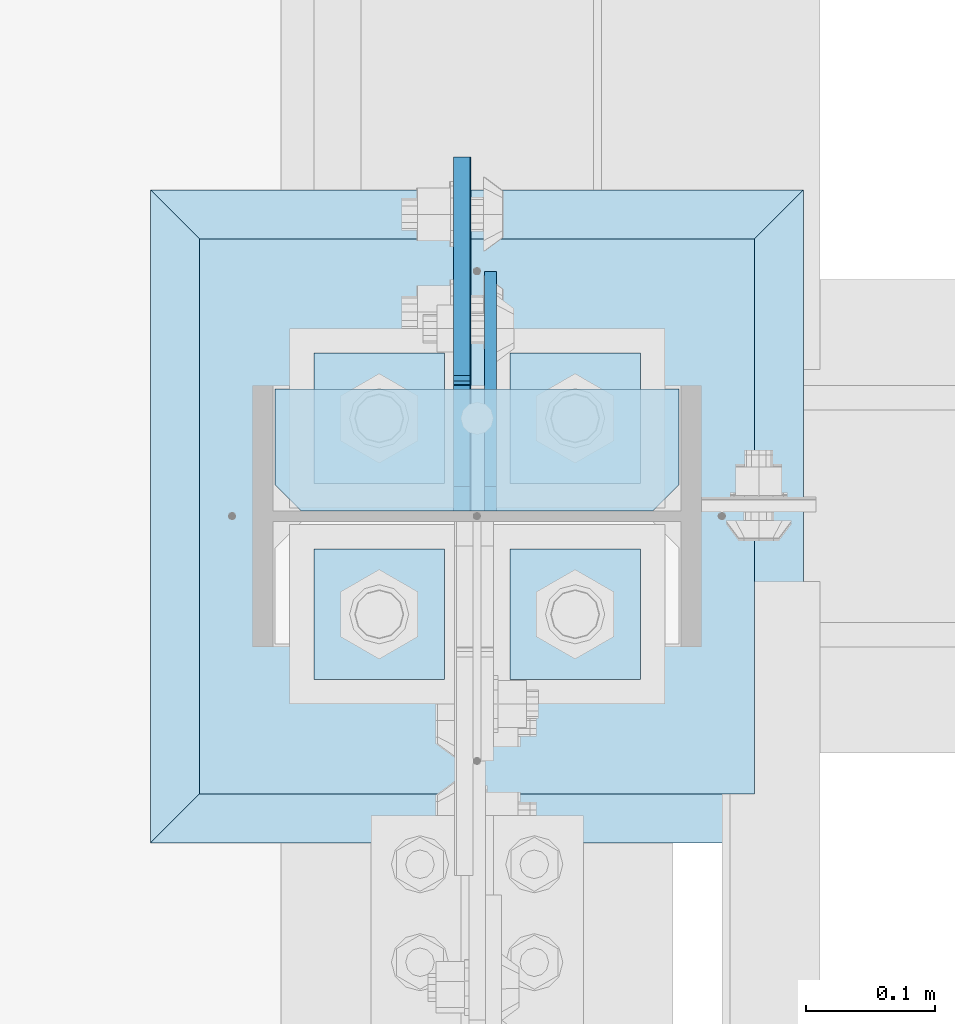
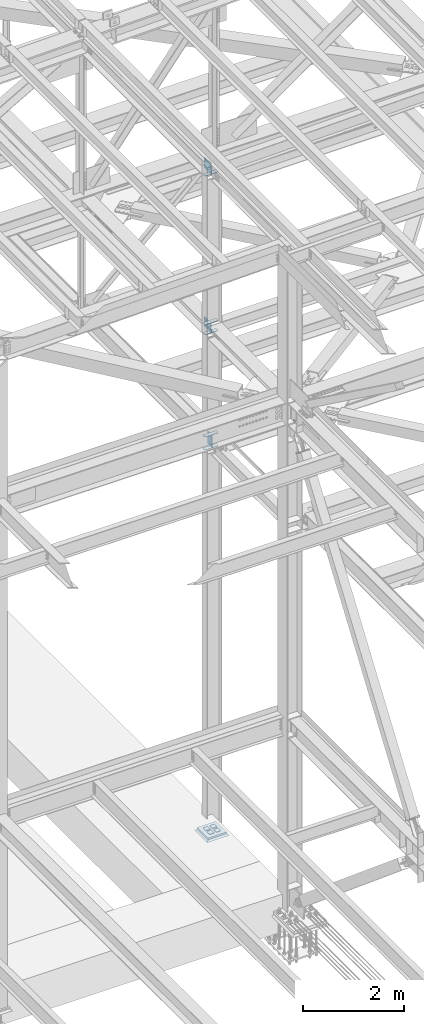
# One storey, part 3203 of 3843: 14 plates, 3 elements without a shape of their own.
"""IFC2X3 building model written with IfcOpenShell, lengths in millimetres."""

from ifc_helpers import new_model, si_unit, frame, origin_with_axes, place, context, subcontext, project, spatial, faceted_brep, material, type_object, element, aggregate, save


model = new_model("IFC2X3")

# Units and contexts
model_context = context("Model", 3, precision=1e-05, world=origin_with_axes())
body_context = subcontext(model_context, "Body", "Model", "MODEL_VIEW")
ifc_project = project(units=[si_unit("LENGTHUNIT", "METRE", prefix="MILLI"), si_unit("AREAUNIT", "SQUARE_METRE"), si_unit("VOLUMEUNIT", "CUBIC_METRE"), si_unit("MASSUNIT", "GRAM", prefix="KILO"), si_unit("TIMEUNIT", "SECOND"), si_unit("PLANEANGLEUNIT", "RADIAN"), si_unit("SOLIDANGLEUNIT", "STERADIAN"), si_unit("THERMODYNAMICTEMPERATUREUNIT", "DEGREE_CELSIUS"), si_unit("LUMINOUSINTENSITYUNIT", "LUMEN")], contexts=[model_context])

# Site, building, storey
site_placement = place(None, origin_with_axes())
site = spatial("IfcSite", under=ifc_project, at=site_placement, CompositionType="ELEMENT")
building_placement = place(site_placement, origin_with_axes())
building = spatial("IfcBuilding", under=site, at=building_placement, Name="Undefined", CompositionType="ELEMENT")
storey_placement = place(building_placement, origin_with_axes())
storey = spatial("IfcBuildingStorey", under=building, at=storey_placement, Name="Undefined", CompositionType="ELEMENT", Elevation=0.0)

# Assembly, plates
assembly_1_placement = place(storey_placement, origin_with_axes())
assembly_1 = element("IfcElementAssembly", 1, at=assembly_1_placement, inside=storey, Name="COLUMN", AssemblyPlace="NOTDEFINED", PredefinedType="RIGID_FRAME")
ifc_material_1 = material(Name="STEEL/A572-50")
plate_type_1 = type_object("IfcPlateType", PredefinedType="NOTDEFINED")
plate_1_placement = place(assembly_1_placement, frame((77169.9625, 28813.91875, 39336.6625), z_axis=(-1.0, 0.0, 0.0), x_axis=(0.0, -1.0, 0.0)))
plate_1 = element("IfcPlate", 2, at=plate_1_placement, type_object=plate_type_1, material=ifc_material_1, Name="PLATE", context=body_context, shape_type="Brep", body=[
    faceted_brep([(0.0, -4.76249999999709, 0.0), (0.0, -4.76249999999709, 314.324999999997), (0.0, 4.76249999999709, 314.324999999997), (0.0, 4.76249999999709, 0.0), (74.6124992370605, -4.76249999999709, 314.324999999997), (74.6124992370605, 4.76249999999709, 314.324999999997), (95.25, -4.76249999999709, 293.687499237058), (95.25, 4.76249999999709, 293.687499237058), (95.25, -4.76249999999709, 20.6375007629395), (95.25, 4.76249999999709, 20.6375007629395), (74.6124992370605, -4.76249999999709, 0.0), (74.6124992370605, 4.76249999999709, 0.0)], [[[0, 1, 2, 3]], [[1, 4, 5, 2]], [[4, 6, 7, 5]], [[6, 8, 9, 7]], [[8, 10, 11, 9]], [[10, 0, 3, 11]], [[5, 7, 9, 11, 3, 2]], [[10, 8, 6, 4, 1, 0]]]),
])
plate_2_placement = place(assembly_1_placement, frame((77169.9625, 28813.91875, 39650.9875), z_axis=(-1.0, 0.0, 0.0), x_axis=(0.0, -1.0, 0.0)))
plate_2 = element("IfcPlate", 3, at=plate_2_placement, type_object=plate_type_1, material=ifc_material_1, Name="PLATE", context=body_context, shape_type="Brep", body=[
    faceted_brep([(0.0, -4.76249999999709, 0.0), (0.0, -4.76249999999709, 314.324999999997), (0.0, 4.76249999999709, 314.324999999997), (0.0, 4.76249999999709, 0.0), (74.6124992370605, -4.76249999999709, 314.324999999997), (74.6124992370605, 4.76249999999709, 314.324999999997), (95.25, -4.76249999999709, 293.687499237058), (95.25, 4.76249999999709, 293.687499237058), (95.25, -4.76249999999709, 20.6375007629395), (95.25, 4.76249999999709, 20.6375007629395), (74.6124992370605, -4.76249999999709, 0.0), (74.6124992370605, 4.76249999999709, 0.0)], [[[0, 1, 2, 3]], [[1, 4, 5, 2]], [[4, 6, 7, 5]], [[6, 8, 9, 7]], [[8, 10, 11, 9]], [[10, 0, 3, 11]], [[5, 7, 9, 11, 3, 2]], [[10, 8, 6, 4, 1, 0]]]),
])

assembly_2_placement = place(storey_placement, origin_with_axes())
assembly_2 = element("IfcElementAssembly", 4, at=assembly_2_placement, inside=storey, Name="TEMPLATE", AssemblyPlace="NOTDEFINED", PredefinedType="RIGID_FRAME")
plate_type_2 = type_object("IfcPlateType", PredefinedType="NOTDEFINED")
plate_3_placement = place(assembly_2_placement, frame((77038.2, 28689.3, 30105.35), z_axis=(0.0, -1.0, 0.0), x_axis=(1.0, 0.0, 0.0)))
plate_3 = element("IfcPlate", 5, at=plate_3_placement, type_object=plate_type_2, material=ifc_material_1, Name="Washer Plate", context=body_context, shape_type="Brep", body=[
    faceted_brep([(0.0, -6.3499999046162, 0.0), (-1.67347025126219e-10, -6.35000000000582, 101.600000000151), (-1.67347025126219e-10, 6.35000000000582, 101.600000000151), (7.27595761418343e-12, 6.3499999046162, 0.0), (101.599998474121, -6.34999999999854, 101.599998474121), (101.599998474121, 6.34999999999854, 101.599998474121), (101.6, -6.34999999999854, 0.0), (101.6, 6.34999999999854, 0.0)], [[[0, 1, 2, 3]], [[1, 4, 5, 2]], [[4, 6, 7, 5]], [[6, 0, 3, 7]], [[5, 7, 3, 2]], [[6, 4, 1, 0]]]),
])
plate_4_placement = place(assembly_2_placement, frame((77038.2, 28841.7, 30105.35), z_axis=(0.0, -1.0, 0.0), x_axis=(1.0, 0.0, 0.0)))
plate_4 = element("IfcPlate", 6, at=plate_4_placement, type_object=plate_type_2, material=ifc_material_1, Name="Washer Plate", context=body_context, shape_type="Brep", body=[
    faceted_brep([(0.0, -6.3499999046162, 0.0), (-1.67347025126219e-10, -6.35000000000582, 101.600000000151), (-1.67347025126219e-10, 6.35000000000582, 101.600000000151), (7.27595761418343e-12, 6.3499999046162, 0.0), (101.599998474121, -6.34999999999854, 101.599998474121), (101.599998474121, 6.34999999999854, 101.599998474121), (101.6, -6.34999999999854, 0.0), (101.6, 6.34999999999854, 0.0)], [[[0, 1, 2, 3]], [[1, 4, 5, 2]], [[4, 6, 7, 5]], [[6, 0, 3, 7]], [[5, 7, 3, 2]], [[6, 4, 1, 0]]]),
])
plate_5_placement = place(assembly_2_placement, frame((76885.8, 28689.3, 30105.35), z_axis=(0.0, -1.0, 0.0), x_axis=(1.0, 0.0, 0.0)))
plate_5 = element("IfcPlate", 7, at=plate_5_placement, type_object=plate_type_2, material=ifc_material_1, Name="Washer Plate", context=body_context, shape_type="Brep", body=[
    faceted_brep([(0.0, -6.3499999046162, 0.0), (-1.67347025126219e-10, -6.35000000000582, 101.600000000151), (-1.67347025126219e-10, 6.35000000000582, 101.600000000151), (7.27595761418343e-12, 6.3499999046162, 0.0), (101.599998474121, -6.34999999999854, 101.599998474121), (101.599998474121, 6.34999999999854, 101.599998474121), (101.6, -6.34999999999854, 0.0), (101.6, 6.34999999999854, 0.0)], [[[0, 1, 2, 3]], [[1, 4, 5, 2]], [[4, 6, 7, 5]], [[6, 0, 3, 7]], [[5, 7, 3, 2]], [[6, 4, 1, 0]]]),
])
plate_6_placement = place(assembly_2_placement, frame((76885.8, 28841.7, 30105.35), z_axis=(0.0, -1.0, 0.0), x_axis=(1.0, 0.0, 0.0)))
plate_6 = element("IfcPlate", 8, at=plate_6_placement, type_object=plate_type_2, material=ifc_material_1, Name="Washer Plate", context=body_context, shape_type="Brep", body=[
    faceted_brep([(0.0, -6.3499999046162, 0.0), (-1.67347025126219e-10, -6.35000000000582, 101.600000000151), (-1.67347025126219e-10, 6.35000000000582, 101.600000000151), (7.27595761418343e-12, 6.3499999046162, 0.0), (101.599998474121, -6.34999999999854, 101.599998474121), (101.599998474121, 6.34999999999854, 101.599998474121), (101.6, -6.34999999999854, 0.0), (101.6, 6.34999999999854, 0.0)], [[[0, 1, 2, 3]], [[1, 4, 5, 2]], [[4, 6, 7, 5]], [[6, 0, 3, 7]], [[5, 7, 3, 2]], [[6, 4, 1, 0]]]),
])
aggregate(assembly_2, [plate_3, plate_4, plate_5, plate_6])

# Plate
plate_type_3 = type_object("IfcPlateType", PredefinedType="NOTDEFINED")
plate_7_placement = place(assembly_1_placement, frame((77169.9625, 28813.91875, 42127.9213145652), z_axis=(-1.0, 0.0, 0.0), x_axis=(0.0, -1.0, 0.0)))
plate_7 = element("IfcPlate", 9, at=plate_7_placement, type_object=plate_type_3, material=ifc_material_1, Name="PLATE", context=body_context, shape_type="Brep", body=[
    faceted_brep([(0.0, -6.3499999046162, 0.0), (-9.13860276341438e-09, -6.34999999999854, 314.324999999808), (-9.13860276341438e-09, 6.34999999999854, 314.324999999808), (7.27595761418343e-12, 6.3499999046162, 0.0), (74.6124992279219, -6.34999999999854, 314.324999999808), (74.6124992279219, 6.34999999999854, 314.324999999808), (95.2499999914617, -6.34999999999854, 293.687499236868), (95.2499999914617, 6.34999999999854, 293.687499236868), (95.2499999993997, -6.34999999999854, 20.6375007629395), (95.2499999993997, 6.34999999999854, 20.6375007629395), (74.6124992370605, -6.34999999999854, 0.0), (74.6124992370605, 6.34999999999854, 0.0)], [[[0, 1, 2, 3]], [[1, 4, 5, 2]], [[4, 6, 7, 5]], [[6, 8, 9, 7]], [[8, 10, 11, 9]], [[10, 0, 3, 11]], [[5, 7, 9, 11, 3, 2]], [[10, 8, 6, 4, 1, 0]]]),
])

plate_8_placement = place(assembly_1_placement, frame((77169.9625, 28813.91875, 42369.2235441763), z_axis=(-1.0, 0.0, 0.0), x_axis=(0.0, -1.0, 0.0)))
plate_8 = element("IfcPlate", 10, at=plate_8_placement, type_object=plate_type_3, material=ifc_material_1, Name="PLATE", context=body_context, shape_type="Brep", body=[
    faceted_brep([(0.0, -6.3499999046162, 0.0), (-9.13860276341438e-09, -6.34999999999854, 314.324999999808), (-9.13860276341438e-09, 6.34999999999854, 314.324999999808), (7.27595761418343e-12, 6.3499999046162, 0.0), (74.6124992279219, -6.34999999999854, 314.324999999808), (74.6124992279219, 6.34999999999854, 314.324999999808), (95.2499999914617, -6.34999999999854, 293.687499236868), (95.2499999914617, 6.34999999999854, 293.687499236868), (95.2499999993997, -6.34999999999854, 20.6375007629395), (95.2499999993997, 6.34999999999854, 20.6375007629395), (74.6124992370605, -6.34999999999854, 0.0), (74.6124992370605, 6.34999999999854, 0.0)], [[[0, 1, 2, 3]], [[1, 4, 5, 2]], [[4, 6, 7, 5]], [[6, 8, 9, 7]], [[8, 10, 11, 9]], [[10, 0, 3, 11]], [[5, 7, 9, 11, 3, 2]], [[10, 8, 6, 4, 1, 0]]]),
])

plate_9_placement = place(assembly_1_placement, frame((77169.9625, 28813.91875, 45969.4788496132), z_axis=(-1.0, 0.0, 0.0), x_axis=(0.0, -1.0, 0.0)))
plate_9 = element("IfcPlate", 11, at=plate_9_placement, type_object=plate_type_3, material=ifc_material_1, Name="PLATE", context=body_context, shape_type="Brep", body=[
    faceted_brep([(0.0, -6.3499999046162, 0.0), (-9.13860276341438e-09, -6.34999999999854, 314.324999999808), (-9.13860276341438e-09, 6.34999999999854, 314.324999999808), (7.27595761418343e-12, 6.3499999046162, 0.0), (74.6124992279219, -6.34999999999854, 314.324999999808), (74.6124992279219, 6.34999999999854, 314.324999999808), (95.2499999914617, -6.34999999999854, 293.687499236868), (95.2499999914617, 6.34999999999854, 293.687499236868), (95.2499999993997, -6.34999999999854, 20.6375007629395), (95.2499999993997, 6.34999999999854, 20.6375007629395), (74.6124992370605, -6.34999999999854, 0.0), (74.6124992370605, 6.34999999999854, 0.0)], [[[0, 1, 2, 3]], [[1, 4, 5, 2]], [[4, 6, 7, 5]], [[6, 8, 9, 7]], [[8, 10, 11, 9]], [[10, 0, 3, 11]], [[5, 7, 9, 11, 3, 2]], [[10, 8, 6, 4, 1, 0]]]),
])

plate_type_4 = type_object("IfcPlateType", PredefinedType="NOTDEFINED")
plate_10_placement = place(assembly_1_placement, frame((77001.6875, 28718.66875, 42153.3213145885), z_axis=(0.0, 0.707106781186548, 0.707106781186548), x_axis=(5.70000238222118e-08, 0.707106781186546, -0.707106781186546)))
plate_10 = element("IfcPlate", 12, at=plate_10_placement, type_object=plate_type_4, material=ifc_material_1, Name="PLATE", context=body_context, shape_type="Brep", body=[
    faceted_brep([(0.0, -6.3499999046162, 0.0), (-134.705418387102, -6.35000000000582, 134.705418387086), (-134.705418387102, 6.35000000000582, 134.705418387086), (7.27595761418343e-12, 6.3499999046162, 0.0), (-134.705418386975, -6.35000000000582, 161.646186750302), (-134.705418386975, 6.35000000000582, 161.646186750302), (46.5835020580871, -6.35000000000582, 342.935107195386), (46.5835020580871, 6.35000000000582, 342.935107195386), (208.228112236558, -6.35000000000582, 181.29049701694), (208.228112236558, 6.35000000000582, 181.29049701694), (26.9407683632217, -6.34999999999854, 1.30967237055302e-10), (26.9407683632217, 6.34999999999854, 1.30967237055302e-10)], [[[0, 1, 2, 3]], [[1, 4, 5, 2]], [[4, 6, 7, 5]], [[6, 8, 9, 7]], [[8, 10, 11, 9]], [[10, 0, 3, 11]], [[5, 7, 9, 11, 3, 2]], [[10, 8, 6, 4, 1, 0]]]),
])

plate_type_5 = type_object("IfcPlateType", PredefinedType="NOTDEFINED")
plate_11_placement = place(assembly_1_placement, frame((77023.11875, 28718.66875, 39360.4750014548), z_axis=(0.0, 0.707106781186548, 0.707106781186548), x_axis=(5.70000238222118e-08, 0.707106781186546, -0.707106781186546)))
plate_11 = element("IfcPlate", 13, at=plate_11_placement, type_object=plate_type_5, material=ifc_material_1, Name="PLATE", context=body_context, shape_type="Brep", body=[
    faceted_brep([(0.0, -4.76249999999709, 0.0), (-188.585379946875, -4.76249999999709, 188.585377136231), (-188.585379946875, 4.76249999999709, 188.585377136231), (0.0, 4.76249999999709, 0.0), (-188.585379946759, -4.76249999999709, 215.526145298725), (-188.585379946759, 4.76249999999709, 215.526145298725), (-70.1582491590088, -4.76249999999709, 333.953276195534), (-70.1582491590088, 4.76249999999709, 333.953276195534), (145.367895960451, -4.76249999999709, 118.427127597391), (145.367895960451, 4.76249999999709, 118.427127597391), (26.9407683631998, -4.76249999999709, 1.30967237055302e-10), (26.9407683631998, 4.76249999999709, 1.30967237055302e-10)], [[[0, 1, 2, 3]], [[1, 4, 5, 2]], [[4, 6, 7, 5]], [[6, 8, 9, 7]], [[8, 10, 11, 9]], [[10, 0, 3, 11]], [[5, 7, 9, 11, 3, 2]], [[10, 8, 6, 4, 1, 0]]]),
])

plate_type_6 = type_object("IfcPlateType", PredefinedType="NOTDEFINED")
plate_12_placement = place(assembly_1_placement, frame((77000.8937499046, 28718.66875, 45994.8788495592), z_axis=(0.0, 0.707106781186548, 0.707106781186548), x_axis=(5.70000238222118e-08, 0.707106781186546, -0.707106781186546)))
plate_12 = element("IfcPlate", 14, at=plate_12_placement, type_object=plate_type_6, material=ifc_material_1, Name="PLATE", context=body_context, shape_type="Brep", body=[
    faceted_brep([(0.0, -6.3499999046162, 0.0), (-161.646427648124, -6.35000000000582, 161.646427648113), (-161.646427648124, 6.35000000000582, 161.646427648113), (7.27595761418343e-12, 6.3499999046162, 0.0), (-161.646427647993, -6.35000000000582, 188.587196011329), (-161.646427647993, 6.35000000000582, 188.587196011329), (-106.081092898559, -6.35000000000582, 244.152530760752), (-106.081092898559, 6.35000000000582, 244.152530760752), (-97.2203407291709, -6.35000000000582, 235.291778591367), (-97.2203407291709, 6.35000000000582, 235.291778591367), (-93.1001642610281, -6.35000000000582, 232.5387646909), (-93.1001642610281, 6.35000000000582, 232.5387646909), (-88.240084742989, -6.35000000000582, 231.572034768316), (-88.240084742989, 6.35000000000582, 231.572034768316), (-83.3800052249608, -6.35000000000582, 232.5387646909), (-83.3800052249608, 6.35000000000582, 232.5387646909), (-79.2598287568107, -6.35000000000582, 235.291778591367), (-79.2598287568107, 6.35000000000582, 235.291778591367), (37.4835009526505, -6.35000000000582, 352.035108300828), (37.4835009526505, 6.35000000000582, 352.035108300828), (208.108367252156, -6.35000000000582, 181.410242001337), (208.108367252156, 6.35000000000582, 181.410242001337), (26.9407683632217, -6.34999999999854, 1.30967237055302e-10), (26.9407683632217, 6.34999999999854, 1.30967237055302e-10)], [[[0, 1, 2, 3]], [[1, 4, 5, 2]], [[4, 6, 7, 5]], [[6, 8, 9, 7]], [[8, 10, 11, 9]], [[10, 12, 13, 11]], [[12, 14, 15, 13]], [[14, 16, 17, 15]], [[16, 18, 19, 17]], [[18, 20, 21, 19]], [[20, 22, 23, 21]], [[22, 0, 3, 23]], [[5, 7, 9, 11, 13, 15, 17, 19, 21, 23, 3, 2]], [[22, 20, 18, 16, 14, 12, 10, 8, 6, 4, 1, 0]]]),
])

plate_type_7 = type_object("IfcPlateType", PredefinedType="NOTDEFINED")
plate_13_placement = place(assembly_1_placement, frame((76796.9, 28498.8, 30079.95), z_axis=(0.0, 1.0, 0.0), x_axis=(1.0, 0.0, 0.0)))
plate_13 = element("IfcPlate", 15, at=plate_13_placement, type_object=plate_type_7, material=ifc_material_1, Name="PLATE", context=body_context, shape_type="Brep", body=[
    faceted_brep([(0.0, -19.0500000000029, 0.0), (0.0, -19.0499999999993, 431.799987792969), (0.0, 19.0499999999993, 431.799987792969), (0.0, 19.0500000000029, 0.0), (431.799987792969, -19.0499999999993, 431.799987792969), (431.799987792969, 19.0499999999993, 431.799987792969), (431.799957275391, -19.0499999999993, 0.0), (431.799957275391, 19.0499999999993, 0.0)], [[[0, 1, 2, 3]], [[1, 4, 5, 2]], [[4, 6, 7, 5]], [[6, 0, 3, 7]], [[5, 7, 3, 2]], [[6, 4, 1, 0]]]),
])

aggregate(assembly_1, [plate_7, plate_8, plate_10, plate_1, plate_2, plate_11, plate_9, plate_12, plate_13])

# Assembly, plate
assembly_3_placement = place(storey_placement, origin_with_axes())
assembly_3 = element("IfcElementAssembly", 16, at=assembly_3_placement, inside=storey, Name="GROUT", AssemblyPlace="NOTDEFINED", PredefinedType="REINFORCEMENT_UNIT")
ifc_material_2 = material(Name="CONCRETE/Concrete_Undefined")
plate_type_8 = type_object("IfcPlateType", PredefinedType="NOTDEFINED")
plate_14_placement = place(assembly_3_placement, frame((76758.8, 28460.7, 30041.85), z_axis=(0.0, 1.0, 0.0), x_axis=(1.0, 0.0, 0.0)))
plate_14 = element("IfcPlate", 17, at=plate_14_placement, type_object=plate_type_8, material=ifc_material_2, Name="GROUT", context=body_context, shape_type="Brep", body=[
    faceted_brep([(38.1000000007043, -19.0499999997883, 469.899999999314), (0.0, 19.0499999999993, 508.0), (0.0, 19.0500000000029, 0.0), (38.1000000006916, -19.0499999999811, 38.1000000006607), (469.899999999325, -19.0499999998174, 38.1000000006607), (508.0, 19.0499999999993, 0.0), (508.0, 19.0499999999993, 508.0), (469.899999999325, -19.0499999999847, 469.899999999314)], [[[0, 1, 2, 3]], [[4, 5, 6, 7]], [[4, 7, 0, 3]], [[5, 4, 3, 2]], [[6, 5, 2, 1]], [[7, 6, 1, 0]]]),
])
aggregate(assembly_3, [plate_14])

save(model, "model.ifc")
